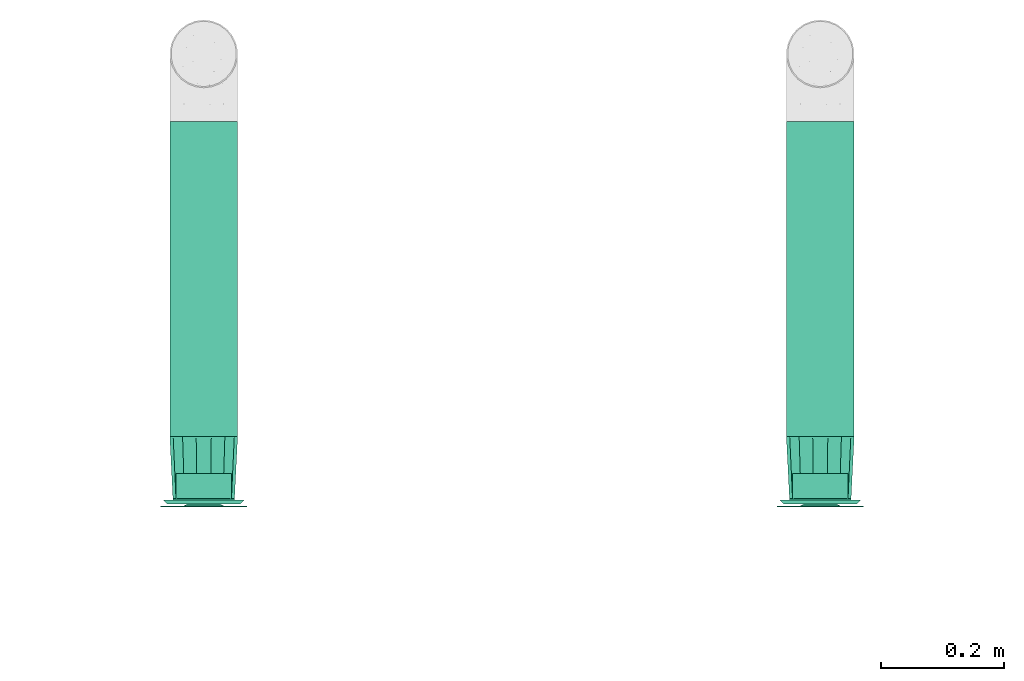
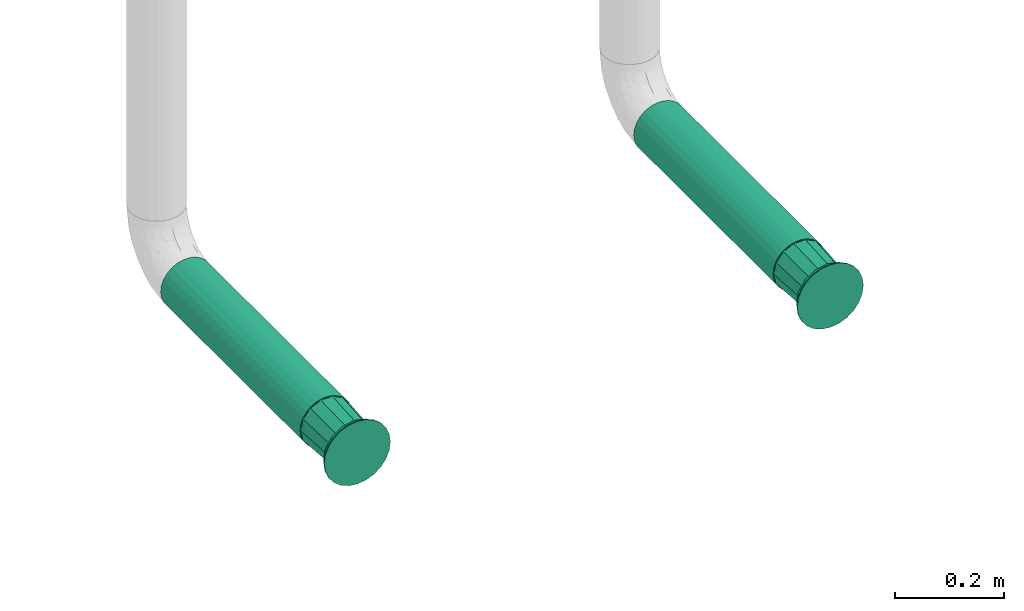
# One storey, part 86 of 115: 2 flow fittings, 2 flow segments, 2 flow terminals.
"""IFC2X3 building model written with IfcOpenShell, lengths in millimetres."""

from ifc_helpers import new_model, entity, si_unit, converted_unit, derived_unit, direction, frame, origin_with_axes, origin_2d_with_axis, place, context, subcontext, project, spatial, hollow_circle, extrude, open_shell, surface_model, source, transform, mapped, material, layer, layer_set, layer_usage, type_object, element, save


model = new_model("IFC2X3")

# Units and contexts
model_context = context("Model", 3, precision=1e-05, world=origin_with_axes(), true_north=direction((0.0, 1.0)))
body_context = subcontext(model_context, "Body", "Model", "MODEL_VIEW")
ifc_project = project(units=[si_unit("AREAUNIT", "SQUARE_METRE"), si_unit("VOLUMEUNIT", "CUBIC_METRE", prefix="DECI"), si_unit("TIMEUNIT", "SECOND"), si_unit("THERMODYNAMICTEMPERATUREUNIT", "DEGREE_CELSIUS"), si_unit("PRESSUREUNIT", "PASCAL"), si_unit("MASSUNIT", "GRAM", prefix="KILO"), si_unit("LENGTHUNIT", "METRE", prefix="MILLI"), si_unit("POWERUNIT", "WATT"), si_unit("ELECTRICCURRENTUNIT", "AMPERE"), si_unit("ELECTRICVOLTAGEUNIT", "VOLT"), derived_unit("VOLUMETRICFLOWRATEUNIT", [(si_unit("VOLUMEUNIT", "CUBIC_METRE", prefix="DECI"), 1), (si_unit("TIMEUNIT", "SECOND"), -1)]), derived_unit("LINEARVELOCITYUNIT", [(si_unit("LENGTHUNIT", "METRE"), 1), (si_unit("TIMEUNIT", "SECOND"), -1)]), derived_unit("MASSDENSITYUNIT", [(si_unit("MASSUNIT", "GRAM", prefix="KILO"), 1), (si_unit("VOLUMEUNIT", "CUBIC_METRE"), -1)]), converted_unit("PLANEANGLEUNIT", "DEGREE", entity("IfcRatioMeasure", 0.01745), si_unit("PLANEANGLEUNIT", "RADIAN"), dimensions=[0, 0, 0, 0, 0, 0, 0])], contexts=[model_context])

# Site, building, storey
site_placement = place(None, origin_with_axes())
site = spatial("IfcSite", under=ifc_project, at=site_placement, CompositionType="ELEMENT")
building_placement = place(site_placement, origin_with_axes())
building = spatial("IfcBuilding", under=site, at=building_placement, Name="mc-building", CompositionType="ELEMENT")
storey_placement = place(building_placement, frame((0.0, 0.0, 2950.0), z_axis=(0.0, 0.0, 1.0), x_axis=(1.0, 0.0, 0.0)))
storey = spatial("IfcBuildingStorey", under=building, at=storey_placement, Name="2. Korrus", CompositionType="ELEMENT", Elevation=2950.0)

# Flow terminals
air_terminal_type = type_object("IfcAirTerminalType", Name="100", PredefinedType="NOTDEFINED")
shared_shape_1 = source(origin_with_axes(), body_context, "Body", "SurfaceModel", [
    surface_model("IfcShellBasedSurfaceModel", [(11.2, 18.11733, -67.61481), (11.2, -18.11733, -67.61481), (11.2, 0.0, -70.0), (11.2, 67.61481, -18.11733), (11.2, 35.0, -60.62178), (11.2, 49.49747, -49.49747), (11.2, 60.62178, -35.0), (11.2, -67.61481, 18.11733), (11.2, -49.49747, -49.49747), (11.2, -67.61481, -18.11733), (11.2, -35.0, -60.62178), (11.2, -60.62178, -35.0), (11.2, -70.0, 0.0), (11.2, 18.11733, 67.61481), (11.2, 70.0, 0.0), (11.2, 67.61481, 18.11733), (11.2, 49.49747, 49.49747), (11.2, 60.62178, 35.0), (11.2, 35.0, 60.62178), (11.2, -49.49747, 49.49747), (11.2, -60.62178, 35.0), (11.2, -35.0, 60.62178), (11.2, -18.11733, 67.61481), (11.2, 0.0, 70.0), (9.2, 18.11733, 67.61481), (9.2, -67.61481, 18.11733), (9.2, 0.0, 70.0), (9.2, 49.49747, 49.49747), (9.2, 35.0, 60.62178), (9.2, 60.62178, 35.0), (9.2, 67.61481, 18.11733), (9.2, -35.0, 60.62178), (9.2, -49.49747, 49.49747), (9.2, -18.11733, 67.61481), (9.2, -60.62178, 35.0), (9.2, -67.61481, -18.11733), (9.2, -70.0, 0.0), (9.2, 67.61481, -18.11733), (9.2, 18.11733, -67.61481), (9.2, 49.49747, -49.49747), (9.2, 60.62178, -35.0), (9.2, 35.0, -60.62178), (9.2, -18.11733, -67.61481), (9.2, -49.49747, -49.49747), (9.2, -60.62178, -35.0), (9.2, -35.0, -60.62178), (9.2, 0.0, -70.0), (9.2, 70.0, 0.0), (9.2, 32.75, 0.0), (9.2, -16.375, 28.36233), (9.2, -28.36233, 16.375), (9.2, 16.375, 28.36233), (9.2, 0.0, 32.75), (9.2, 28.36233, 16.375), (9.2, -32.75, 0.0), (9.2, -16.375, -28.36233), (9.2, 16.375, -28.36233), (9.2, 0.0, -32.75), (9.2, 28.36233, -16.375), (9.2, -28.36233, -16.375), (6.2, -21.19625, -15.39997), (6.2, -21.19625, 15.39997), (6.2, 8.09625, 24.91768), (6.2, -8.09625, 24.91768), (6.2, -26.2, 0.0), (6.2, 21.19625, 15.39997), (6.2, -8.09625, -24.91768), (6.2, 21.19625, -15.39997), (6.2, 8.09625, -24.91768), (6.2, 26.2, 0.0), (9.2, 31.06579, -6.28555), (6.2, 23.69812, -7.69999), (6.2, -14.64625, -20.15883), (9.2, -22.36867, -22.36867), (6.2, -23.69812, -7.69999), (9.2, -31.06579, -6.28555), (6.2, 14.64625, -20.15883), (9.2, 8.1875, -30.55617), (6.2, 0.0, -24.91768), (9.2, 22.36867, -22.36867), (9.2, -8.1875, -30.55617), (9.2, -31.06579, 6.28555), (6.2, -23.69812, 7.69999), (6.2, 14.64625, 20.15883), (9.2, 22.36867, 22.36867), (6.2, 23.69812, 7.69999), (9.2, 31.06579, 6.28555), (6.2, -14.64625, 20.15883), (9.2, -8.1875, 30.55617), (6.2, 0.0, 24.91768), (9.2, -22.36867, 22.36867), (9.2, 8.1875, 30.55617), (6.2, -13.11761, 57.472), (6.2, -36.75472, 46.08897), (6.2, -53.11211, 25.57744), (6.2, 36.75472, 46.08897), (6.2, -58.95, 0.0), (6.2, 13.11761, 57.472), (6.2, 53.11211, 25.57744), (6.2, -53.11211, -25.57744), (6.2, -36.75472, -46.08897), (6.2, -13.11761, -57.472), (6.2, 58.95, 0.0), (6.2, 53.11211, -25.57744), (6.2, 13.11761, -57.472), (6.2, 36.75472, -46.08897), (0.0, -60.51411, 25.06576), (0.0, 0.0, 65.5), (0.0, 25.06576, 60.51411), (0.0, 46.3155, 46.3155), (0.0, 60.51411, 25.06576), (0.0, -46.3155, 46.3155), (0.0, -25.06576, 60.51411), (0.0, 0.0, -65.5), (0.0, -65.5, 0.0), (0.0, 65.5, 0.0), (0.0, 60.51411, -25.06576), (0.0, 46.3155, -46.3155), (0.0, 25.06576, -60.51411), (0.0, -46.3155, -46.3155), (0.0, -60.51411, -25.06576), (0.0, -25.06576, -60.51411), (6.2, 56.03105, -12.78872), (0.0, 53.4148, -35.69063), (0.0, 35.69063, -53.4148), (6.2, 24.93616, -51.78048), (0.0, -12.53288, -63.00706), (6.2, 0.0, -57.472), (0.0, -35.69063, -53.4148), (0.0, 63.00706, -12.53288), (6.2, 44.93342, -35.83321), (6.2, -24.93616, -51.78048), (6.2, -44.93342, -35.83321), (0.0, -53.4148, -35.69063), (0.0, 12.53288, -63.00706), (6.2, -56.03105, -12.78872), (0.0, -63.00706, -12.53288), (6.2, -56.03105, 12.78872), (0.0, -53.4148, 35.69063), (0.0, -35.69063, 53.4148), (6.2, -24.93616, 51.78048), (0.0, 12.53288, 63.00706), (6.2, 0.0, 57.472), (0.0, 35.69063, 53.4148), (0.0, -63.00706, 12.53288), (6.2, -44.93342, 35.83321), (6.2, 24.93616, 51.78048), (6.2, 44.93342, 35.83321), (0.0, 53.4148, 35.69063), (0.0, -12.53288, 63.00706), (6.2, 56.03105, 12.78872), (0.0, 63.00706, 12.53288), (-3.1, 12.94095, 48.29629), (-3.1, -35.35534, 35.35534), (-3.1, 0.0, 50.0), (-3.1, 35.35534, 35.35534), (-3.1, 25.0, 43.30127), (-3.1, -43.30127, 25.0), (-3.1, 43.30127, 25.0), (-3.1, -48.29629, -12.94095), (-3.1, -12.94095, 48.29629), (-3.1, -25.0, 43.30127), (-3.1, -50.0, 0.0), (-3.1, -48.29629, 12.94095), (-3.1, 48.29629, 12.94095), (-3.1, 12.94095, -48.29629), (-3.1, 50.0, 0.0), (-3.1, 48.29629, -12.94095), (-3.1, 35.35534, -35.35534), (-3.1, 43.30127, -25.0), (-3.1, 25.0, -43.30127), (-3.1, 0.0, -50.0), (-3.1, -35.35534, -35.35534), (-3.1, -43.30127, -25.0), (-3.1, -25.0, -43.30127), (-3.1, -12.94095, -48.29629), (0.0, 25.0, -43.30127), (0.0, 0.0, -50.0), (0.0, 12.94095, -48.29629), (0.0, 48.29629, -12.94095), (0.0, 35.35534, -35.35534), (0.0, -25.0, -43.30127), (0.0, 43.30127, -25.0), (0.0, -50.0, 0.0), (0.0, -12.94095, -48.29629), (0.0, -35.35534, -35.35534), (0.0, -48.29629, -12.94095), (0.0, -43.30127, -25.0), (0.0, 50.0, 0.0), (0.0, 43.30127, 25.0), (0.0, 12.94095, 48.29629), (0.0, 35.35534, 35.35534), (0.0, 25.0, 43.30127), (0.0, 0.0, 50.0), (0.0, -35.35534, 35.35534), (0.0, -43.30127, 25.0), (0.0, -48.29629, 12.94095), (0.0, -12.94095, 48.29629), (0.0, -25.0, 43.30127), (0.0, 48.29629, 12.94095), (-43.1, 0.0, 45.0), (-43.1, 11.64686, 43.46666), (-43.1, 22.5, 38.97115), (-43.1, -11.64686, 43.46666), (-43.1, 38.97115, 22.5), (-43.1, 43.46666, 11.64686), (-43.1, 31.81981, 31.81981), (-43.1, -22.5, 38.97115), (-43.1, -43.46666, 11.64686), (-43.1, -31.81981, 31.81981), (-43.1, -38.97115, 22.5), (-43.1, -45.0, 0.0), (-43.1, -43.46666, -11.64686), (-43.1, 45.0, 0.0), (-43.1, 43.46666, -11.64686), (-43.1, 38.97115, -22.5), (-43.1, 31.81981, -31.81981), (-43.1, 22.5, -38.97115), (-43.1, 11.64686, -43.46666), (-43.1, -31.81981, -31.81981), (-43.1, -38.97115, -22.5), (-43.1, -22.5, -38.97115), (-43.1, 0.0, -45.0), (-43.1, -11.64686, -43.46666), (-3.1, 22.5, -38.97115), (-3.1, 0.0, -45.0), (-3.1, 11.64686, -43.46666), (-3.1, 31.81981, -31.81981), (-3.1, -22.5, -38.97115), (-3.1, 38.97115, -22.5), (-3.1, 43.46666, -11.64686), (-3.1, 45.0, 0.0), (-3.1, -45.0, 0.0), (-3.1, -11.64686, -43.46666), (-3.1, -31.81981, -31.81981), (-3.1, -43.46666, -11.64686), (-3.1, -38.97115, -22.5), (-3.1, 0.0, 45.0), (-3.1, 43.46666, 11.64686), (-3.1, 38.97115, 22.5), (-3.1, 22.5, 38.97115), (-3.1, 31.81981, 31.81981), (-3.1, 11.64686, 43.46666), (-3.1, -11.64686, 43.46666), (-3.1, -43.46666, 11.64686), (-3.1, -31.81981, 31.81981), (-3.1, -38.97115, 22.5), (-3.1, -22.5, 38.97115)], [open_shell([[[0, 1, 2]], [[3, 0, 4]], [[5, 6, 3]], [[5, 3, 4]], [[7, 1, 0]], [[8, 7, 9]], [[10, 7, 8]], [[8, 9, 11]], [[12, 9, 7]], [[1, 7, 10]], [[7, 0, 3]], [[13, 14, 15]], [[16, 15, 17]], [[16, 18, 13]], [[16, 13, 15]], [[14, 13, 7]], [[7, 19, 20]], [[19, 7, 21]], [[7, 22, 21]], [[22, 7, 23]], [[7, 13, 23]], [[14, 7, 3]], [[24, 25, 26]], [[27, 24, 28]], [[27, 29, 30]], [[27, 30, 24]], [[25, 24, 30]], [[31, 25, 32]], [[25, 31, 33]], [[32, 25, 34]], [[33, 26, 25]], [[25, 35, 36]], [[25, 30, 37]], [[25, 37, 38]], [[39, 37, 40]], [[39, 41, 38]], [[39, 38, 37]], [[38, 42, 25]], [[35, 43, 44]], [[35, 25, 43]], [[45, 43, 25]], [[42, 45, 25]], [[38, 46, 42]], [[37, 30, 47]], [[35, 9, 36]], [[44, 11, 35]], [[10, 43, 45]], [[44, 43, 8]], [[1, 45, 42]], [[35, 11, 9]], [[9, 12, 36]], [[1, 10, 45]], [[8, 43, 10]], [[8, 11, 44]], [[2, 1, 42]], [[42, 46, 2]], [[38, 0, 46]], [[41, 4, 38]], [[6, 39, 40]], [[41, 39, 5]], [[3, 40, 37]], [[41, 5, 4]], [[4, 0, 38]], [[14, 3, 37]], [[6, 40, 3]], [[6, 5, 39]], [[47, 14, 37]], [[46, 0, 2]], [[30, 15, 47]], [[29, 17, 30]], [[18, 27, 28]], [[29, 27, 16]], [[13, 28, 24]], [[30, 17, 15]], [[15, 14, 47]], [[13, 18, 28]], [[16, 27, 18]], [[16, 17, 29]], [[23, 13, 24]], [[24, 26, 23]], [[33, 22, 26]], [[31, 21, 33]], [[20, 32, 34]], [[31, 32, 19]], [[7, 34, 25]], [[31, 19, 21]], [[21, 22, 33]], [[12, 7, 25]], [[20, 34, 7]], [[20, 19, 32]], [[36, 12, 25]], [[26, 22, 23]], [[48, 49, 50]], [[48, 51, 49]], [[49, 51, 52]], [[53, 51, 48]], [[48, 50, 54]], [[54, 55, 48]], [[56, 55, 57]], [[55, 58, 48]], [[58, 55, 56]], [[55, 54, 59]], [[60, 61, 62]], [[62, 61, 63]], [[64, 61, 60]], [[62, 65, 66]], [[67, 68, 65]], [[66, 60, 62]], [[65, 68, 66]], [[69, 67, 65]], [[69, 48, 70]], [[58, 71, 70]], [[72, 73, 60]], [[59, 74, 60]], [[75, 64, 74]], [[56, 68, 76]], [[72, 66, 55]], [[73, 72, 55]], [[68, 77, 78]], [[64, 75, 54]], [[59, 75, 74]], [[70, 71, 69]], [[67, 79, 76]], [[80, 55, 66]], [[68, 56, 77]], [[56, 76, 79]], [[79, 67, 58]], [[71, 58, 67]], [[80, 78, 57]], [[77, 57, 78]], [[66, 78, 80]], [[59, 60, 73]], [[64, 54, 81]], [[50, 82, 81]], [[83, 84, 65]], [[53, 85, 65]], [[86, 69, 85]], [[49, 63, 87]], [[83, 62, 51]], [[84, 83, 51]], [[63, 88, 89]], [[69, 86, 48]], [[53, 86, 85]], [[81, 82, 64]], [[61, 90, 87]], [[91, 51, 62]], [[63, 49, 88]], [[49, 87, 90]], [[90, 61, 50]], [[82, 50, 61]], [[91, 89, 52]], [[88, 52, 89]], [[62, 89, 91]], [[53, 65, 84]], [[92, 93, 94]], [[95, 94, 96]], [[97, 92, 95]], [[95, 92, 94]], [[96, 98, 95]], [[96, 99, 98]], [[99, 100, 101]], [[101, 102, 98]], [[102, 101, 103]], [[104, 105, 103]], [[101, 104, 103]], [[101, 98, 99]], [[106, 107, 108]], [[109, 110, 108]], [[106, 108, 110]], [[111, 112, 106]], [[106, 112, 107]], [[106, 113, 114]], [[106, 110, 113]], [[115, 116, 117]], [[117, 113, 110]], [[113, 117, 118]], [[114, 119, 120]], [[121, 119, 114]], [[121, 114, 113]], [[115, 117, 110]], [[103, 116, 122]], [[123, 116, 103]], [[124, 125, 118]], [[101, 126, 127]], [[100, 119, 128]], [[102, 122, 129]], [[103, 130, 123]], [[102, 129, 115]], [[113, 127, 126]], [[125, 124, 105]], [[130, 105, 117]], [[118, 125, 104]], [[124, 117, 105]], [[131, 100, 128]], [[119, 100, 132]], [[133, 99, 120]], [[134, 118, 104]], [[122, 116, 129]], [[127, 134, 104]], [[131, 121, 101]], [[99, 133, 132]], [[128, 121, 131]], [[130, 117, 123]], [[101, 121, 126]], [[99, 135, 120]], [[96, 136, 135]], [[136, 120, 135]], [[134, 127, 113]], [[133, 119, 132]], [[136, 96, 114]], [[94, 106, 137]], [[138, 106, 94]], [[139, 140, 112]], [[97, 141, 142]], [[95, 109, 143]], [[96, 137, 144]], [[94, 145, 138]], [[96, 144, 114]], [[107, 142, 141]], [[140, 139, 93]], [[145, 93, 111]], [[112, 140, 92]], [[139, 111, 93]], [[146, 95, 143]], [[109, 95, 147]], [[148, 98, 110]], [[149, 112, 92]], [[137, 106, 144]], [[142, 149, 92]], [[146, 108, 97]], [[98, 148, 147]], [[143, 108, 146]], [[145, 111, 138]], [[97, 108, 141]], [[98, 150, 110]], [[102, 151, 150]], [[151, 110, 150]], [[149, 142, 107]], [[148, 109, 147]], [[151, 102, 115]], [[152, 153, 154]], [[155, 152, 156]], [[157, 152, 158]], [[158, 152, 155]], [[158, 159, 157]], [[160, 153, 161]], [[160, 154, 153]], [[157, 162, 163]], [[153, 152, 157]], [[157, 159, 162]], [[158, 164, 159]], [[165, 166, 167]], [[168, 167, 169]], [[170, 165, 167]], [[170, 167, 168]], [[166, 165, 171]], [[159, 172, 173]], [[172, 159, 174]], [[174, 171, 175]], [[159, 164, 174]], [[166, 171, 174]], [[174, 164, 166]], [[176, 177, 178]], [[179, 176, 180]], [[176, 179, 181]], [[179, 180, 182]], [[179, 183, 181]], [[177, 181, 184]], [[177, 176, 181]], [[185, 186, 187]], [[186, 185, 181]], [[181, 183, 186]], [[183, 179, 188]], [[183, 188, 189]], [[190, 189, 191]], [[189, 190, 183]], [[190, 191, 192]], [[193, 194, 190]], [[183, 195, 196]], [[183, 190, 195]], [[194, 197, 198]], [[194, 195, 190]], [[197, 194, 193]], [[189, 188, 199]], [[164, 199, 166]], [[158, 189, 164]], [[192, 155, 156]], [[158, 155, 191]], [[190, 156, 152]], [[164, 189, 199]], [[199, 188, 166]], [[190, 192, 156]], [[191, 155, 192]], [[191, 189, 158]], [[193, 190, 152]], [[152, 154, 193]], [[160, 197, 154]], [[161, 198, 160]], [[195, 153, 157]], [[161, 153, 194]], [[196, 157, 163]], [[161, 194, 198]], [[198, 197, 160]], [[183, 196, 163]], [[195, 157, 196]], [[195, 194, 153]], [[162, 183, 163]], [[154, 197, 193]], [[159, 186, 162]], [[173, 187, 159]], [[181, 172, 174]], [[173, 172, 185]], [[184, 174, 175]], [[159, 187, 186]], [[186, 183, 162]], [[184, 181, 174]], [[185, 172, 181]], [[185, 187, 173]], [[177, 184, 175]], [[175, 171, 177]], [[165, 178, 171]], [[170, 176, 165]], [[182, 168, 169]], [[170, 168, 180]], [[179, 169, 167]], [[170, 180, 176]], [[176, 178, 165]], [[188, 179, 167]], [[182, 169, 179]], [[182, 180, 168]], [[166, 188, 167]], [[171, 178, 177]], [[200, 201, 202]], [[203, 200, 202]], [[204, 205, 202]], [[204, 202, 206]], [[203, 202, 205]], [[207, 208, 209]], [[207, 203, 205]], [[209, 208, 210]], [[211, 208, 212]], [[208, 207, 212]], [[207, 205, 212]], [[213, 214, 215]], [[205, 215, 212]], [[212, 216, 217]], [[216, 212, 215]], [[218, 219, 217]], [[212, 219, 220]], [[212, 217, 219]], [[221, 222, 223]], [[222, 221, 219]], [[218, 222, 219]], [[215, 205, 213]], [[224, 225, 226]], [[227, 228, 224]], [[229, 230, 231]], [[228, 227, 229]], [[229, 232, 228]], [[225, 228, 233]], [[225, 224, 228]], [[234, 235, 236]], [[235, 234, 228]], [[228, 232, 235]], [[232, 229, 231]], [[237, 238, 239]], [[240, 239, 241]], [[240, 242, 237]], [[240, 237, 239]], [[238, 237, 243]], [[244, 245, 246]], [[247, 244, 232]], [[244, 247, 245]], [[232, 238, 247]], [[238, 243, 247]], [[238, 232, 231]], [[205, 238, 213]], [[204, 239, 205]], [[240, 206, 202]], [[204, 206, 241]], [[242, 202, 201]], [[205, 239, 238]], [[238, 231, 213]], [[240, 202, 242]], [[241, 206, 240]], [[241, 239, 204]], [[201, 237, 242]], [[201, 200, 237]], [[243, 203, 207]], [[209, 247, 207]], [[246, 210, 208]], [[209, 210, 245]], [[244, 208, 211]], [[203, 243, 200]], [[207, 247, 243]], [[200, 243, 237]], [[209, 245, 247]], [[210, 246, 245]], [[244, 246, 208]], [[211, 232, 244]], [[212, 235, 211]], [[220, 236, 212]], [[228, 219, 221]], [[220, 219, 234]], [[233, 221, 223]], [[212, 236, 235]], [[235, 232, 211]], [[233, 228, 221]], [[234, 219, 228]], [[234, 236, 220]], [[225, 233, 223]], [[223, 222, 225]], [[226, 218, 217]], [[216, 224, 217]], [[229, 215, 214]], [[216, 215, 227]], [[230, 214, 213]], [[218, 226, 222]], [[217, 224, 226]], [[222, 226, 225]], [[216, 227, 224]], [[215, 229, 227]], [[230, 229, 214]], [[213, 231, 230]]])]),
])
for number, where, z_axis, x_axis, name in (
    (1, (23757.14677, 12939.66532, 2300.0), (0.0, 0.0, 1.0), (0.0, -1.0, 0.0), "100"),
    (2, (22757.14677, 12939.66532, 2300.0), (0.0, 0.0, 1.0), (0.0, -1.0, 0.0), "100"),
):
    element("IfcFlowTerminal", number, at=place(storey_placement, frame(where, z_axis=z_axis, x_axis=x_axis)), inside=storey, type_object=air_terminal_type, Name=name, context=body_context, shape_type="MappedRepresentation", body=[
        mapped(shared_shape_1, transform((0.0, 0.0, 0.0), scale=1.0)),
    ])

# Flow segments
ifc_material = material(Name="FZ1")
ifc_layer = layer(ifc_material, 0.0)
ifc_layer_set = layer_set([ifc_layer], Name="FZ1")
ifc_layer_usage = layer_usage(ifc_layer_set, "AXIS1", "POSITIVE", 0.0)
duct_segment_type = type_object("IfcDuctSegmentType", PredefinedType="RIGIDSEGMENT")
shared_shape_2 = source(origin_with_axes(), body_context, "Body", "SweptSolid", [
    extrude(hollow_circle(Radius=55.0, WallThickness=2.0, at=origin_2d_with_axis()), frame((0.0, 0.0, 0.0), z_axis=(1.0, 0.0, 0.0), x_axis=(0.0, 1.0, 0.0)), (0.0, 0.0, 1.0), 510.8),
])
for number, where, z_axis, x_axis in (
    (3, (23757.14677, 13042.76532, 2300.0), (0.0, 0.0, 1.0), (0.0, 1.0, 0.0)),
    (4, (22757.14677, 13042.76532, 2300.0), (0.0, 0.0, 1.0), (0.0, 1.0, 0.0)),
):
    element("IfcFlowSegment", number, at=place(storey_placement, frame(where, z_axis=z_axis, x_axis=x_axis)), inside=storey, type_object=duct_segment_type, material=ifc_layer_usage, context=body_context, shape_type="MappedRepresentation", body=[
        mapped(shared_shape_2, transform((0.0, 0.0, 0.0), scale=1.0)),
    ])

# Flow fittings
duct_fitting_type = type_object("IfcDuctFittingType", PredefinedType="TRANSITION")
shared_shape_3 = source(origin_with_axes(), body_context, "Body", "SurfaceModel", [
    surface_model("IfcShellBasedSurfaceModel", [(0.0, 12.94095, 48.29629), (0.0, -35.35534, 35.35534), (0.0, 0.0, 50.0), (0.0, 35.35534, 35.35534), (0.0, 25.0, 43.30127), (0.0, 43.30127, 25.0), (0.0, 48.29629, 12.94095), (0.0, -12.94095, 48.29629), (0.0, -25.0, 43.30127), (0.0, -48.29629, 12.94095), (0.0, -43.30127, 25.0), (0.0, -25.0, -43.30127), (0.0, -48.29629, -12.94095), (0.0, -50.0, 0.0), (0.0, 48.29629, -12.94095), (0.0, 12.94095, -48.29629), (0.0, 43.30127, -25.0), (0.0, 35.35534, -35.35534), (0.0, 25.0, -43.30127), (0.0, -35.35534, -35.35534), (0.0, -43.30127, -25.0), (0.0, -12.94095, -48.29629), (0.0, 0.0, -50.0), (0.0, 50.0, 0.0), (100.0, -55.0, 0.0), (100.0, -12.23865, 53.62104), (100.0, -34.29194, 43.00073), (100.0, 49.55329, -23.86361), (100.0, 12.23865, 53.62104), (100.0, 34.29194, 43.00073), (100.0, 55.0, 0.0), (100.0, 49.55329, 23.86361), (100.0, -49.55329, 23.86361), (100.0, 12.23865, -53.62104), (100.0, -49.55329, -23.86361), (100.0, -34.29194, -43.00073), (100.0, 34.29194, -43.00073), (100.0, -12.23865, -53.62104), (0.0, 11.12605, 48.7464), (0.0, -11.12605, 48.7464), (0.0, 31.17449, 39.09157), (0.0, -45.04844, -21.69419), (0.0, -45.04844, 21.69419), (0.0, -31.17449, 39.09157), (0.0, 45.04844, 21.69419), (0.0, 45.04844, -21.69419), (0.0, 31.17449, -39.09157), (0.0, -31.17449, -39.09157), (0.0, -11.12605, -48.7464), (0.0, 11.12605, -48.7464), (0.0, -47.52422, -10.84709), (100.0, -41.92261, -33.43217), (0.0, -38.11147, -30.39288), (100.0, 41.92261, -33.43217), (0.0, 38.11147, -30.39288), (0.0, -21.15027, -43.91899), (100.0, -23.2653, -48.31088), (100.0, -52.32388, -11.72483), (100.0, 0.0, -53.62104), (0.0, 0.0, -48.7464), (100.0, 23.2653, -48.31088), (0.0, 21.15027, -43.91899), (100.0, 52.32388, -11.72483), (0.0, 47.52422, -10.84709), (0.0, 47.52422, 10.84709), (100.0, 41.92261, 33.43217), (0.0, 38.11147, 30.39288), (100.0, -41.92261, 33.43217), (0.0, -38.11147, 30.39288), (0.0, 21.15027, 43.91899), (100.0, 23.2653, 48.31088), (100.0, 52.32388, 11.72483), (100.0, 0.0, 53.62104), (0.0, 0.0, 48.7464), (100.0, -23.2653, 48.31088), (0.0, -21.15027, 43.91899), (100.0, -52.32388, 11.72483), (0.0, -47.52422, 10.84709), (100.0, 27.5, -47.63139), (100.0, 0.0, -55.0), (100.0, 14.23505, -53.12592), (100.0, 38.89087, -38.89087), (100.0, -27.5, -47.63139), (100.0, 47.63139, -27.5), (100.0, 53.12592, -14.23505), (100.0, -14.23505, -53.12592), (100.0, -47.63139, -27.5), (100.0, -38.89087, -38.89087), (100.0, -53.12592, -14.23505), (100.0, 53.12592, 14.23505), (100.0, 47.63139, 27.5), (100.0, 27.5, 47.63139), (100.0, 38.89087, 38.89087), (100.0, 14.23505, 53.12592), (100.0, 0.0, 55.0), (100.0, -47.63139, 27.5), (100.0, -53.12592, 14.23505), (100.0, -27.5, 47.63139), (100.0, -38.89087, 38.89087), (100.0, -14.23505, 53.12592), (98.0, 0.0, 55.0), (98.0, 14.23505, 53.12592), (98.0, 27.5, 47.63139), (98.0, 38.89087, 38.89087), (98.0, 47.63139, 27.5), (98.0, -47.63139, 27.5), (98.0, 53.12592, -14.23505), (98.0, -27.5, 47.63139), (98.0, -14.23505, 53.12592), (98.0, -38.89087, 38.89087), (98.0, -55.0, 0.0), (98.0, -53.12592, 14.23505), (98.0, 53.12592, 14.23505), (98.0, 47.63139, -27.5), (98.0, -27.5, -47.63139), (98.0, 0.0, -55.0), (98.0, 38.89087, -38.89087), (98.0, 27.5, -47.63139), (98.0, 14.23505, -53.12592), (98.0, -47.63139, -27.5), (98.0, -38.89087, -38.89087), (98.0, -53.12592, -14.23505), (98.0, -14.23505, -53.12592), (98.0, 55.0, 0.0), (2.0, 12.94095, -48.29629), (2.0, 25.0, -43.30127), (2.0, 35.35534, -35.35534), (2.0, 43.30127, -25.0), (2.0, 48.29629, -12.94095), (2.0, 0.0, -50.0), (2.0, 50.0, 0.0), (2.0, -25.0, -43.30127), (2.0, -12.94095, -48.29629), (2.0, -35.35534, -35.35534), (2.0, -48.29629, -12.94095), (2.0, -43.30127, -25.0), (2.0, -48.29629, 12.94095), (2.0, 48.29629, 12.94095), (2.0, 43.30127, 25.0), (2.0, 35.35534, 35.35534), (2.0, -35.35534, 35.35534), (2.0, 12.94095, 48.29629), (2.0, 25.0, 43.30127), (2.0, 0.0, 50.0), (2.0, -43.30127, 25.0), (2.0, -50.0, 0.0), (2.0, -12.94095, 48.29629), (2.0, -25.0, 43.30127)], [open_shell([[[0, 1, 2]], [[3, 0, 4]], [[3, 5, 6]], [[0, 3, 1]], [[6, 1, 3]], [[7, 1, 8]], [[7, 2, 1]], [[1, 9, 10]], [[9, 1, 11]], [[12, 13, 9]], [[11, 1, 6]], [[6, 14, 11]], [[15, 14, 16]], [[17, 18, 15]], [[17, 15, 16]], [[11, 14, 15]], [[12, 19, 20]], [[19, 12, 11]], [[15, 21, 11]], [[12, 9, 11]], [[22, 21, 15]], [[14, 6, 23]], [[24, 25, 26]], [[25, 27, 28]], [[29, 28, 27]], [[27, 30, 31]], [[31, 29, 27]], [[24, 26, 32]], [[33, 24, 34]], [[33, 34, 35]], [[36, 27, 33]], [[33, 27, 24]], [[35, 37, 33]], [[24, 27, 25]], [[38, 23, 39]], [[40, 23, 38]], [[41, 42, 43]], [[41, 13, 42]], [[23, 43, 39]], [[40, 44, 23]], [[41, 23, 45]], [[41, 45, 46]], [[47, 41, 48]], [[49, 48, 41]], [[41, 46, 49]], [[23, 41, 43]], [[34, 50, 41]], [[47, 51, 52]], [[45, 27, 53]], [[36, 54, 53]], [[55, 48, 56]], [[34, 57, 50]], [[57, 13, 50]], [[13, 57, 24]], [[55, 35, 47]], [[35, 51, 47]], [[51, 41, 52]], [[58, 59, 49]], [[60, 61, 46]], [[37, 59, 58]], [[62, 63, 23]], [[35, 55, 56]], [[23, 30, 62]], [[53, 54, 45]], [[48, 37, 56]], [[33, 49, 61]], [[49, 33, 58]], [[54, 36, 46]], [[63, 27, 45]], [[34, 41, 51]], [[33, 61, 60]], [[48, 59, 37]], [[27, 63, 62]], [[46, 36, 60]], [[31, 64, 44]], [[40, 65, 66]], [[42, 32, 67]], [[26, 68, 67]], [[69, 38, 70]], [[31, 71, 64]], [[71, 23, 64]], [[23, 71, 30]], [[69, 29, 40]], [[29, 65, 40]], [[65, 44, 66]], [[72, 73, 39]], [[74, 75, 43]], [[28, 73, 72]], [[76, 77, 13]], [[29, 69, 70]], [[13, 24, 76]], [[67, 68, 42]], [[38, 28, 70]], [[25, 39, 75]], [[39, 25, 72]], [[68, 26, 43]], [[77, 32, 42]], [[31, 44, 65]], [[25, 75, 74]], [[38, 73, 28]], [[32, 77, 76]], [[43, 26, 74]], [[78, 79, 80]], [[81, 82, 78]], [[82, 83, 84]], [[81, 83, 82]], [[30, 82, 84]], [[79, 82, 85]], [[79, 78, 82]], [[82, 86, 87]], [[82, 30, 86]], [[24, 88, 86]], [[86, 30, 89]], [[90, 24, 89]], [[91, 90, 92]], [[91, 93, 94]], [[90, 91, 24]], [[94, 95, 91]], [[24, 95, 96]], [[24, 91, 95]], [[94, 97, 98]], [[98, 95, 94]], [[97, 94, 99]], [[89, 24, 86]], [[100, 101, 102]], [[100, 102, 103]], [[100, 104, 105]], [[104, 100, 103]], [[106, 105, 104]], [[100, 107, 108]], [[100, 109, 107]], [[105, 110, 111]], [[109, 100, 105]], [[105, 106, 110]], [[106, 104, 112]], [[106, 113, 110]], [[113, 114, 110]], [[115, 116, 117]], [[113, 116, 115]], [[117, 118, 115]], [[119, 114, 120]], [[121, 110, 119]], [[114, 115, 122]], [[119, 110, 114]], [[115, 114, 113]], [[123, 106, 112]], [[121, 88, 110]], [[119, 86, 121]], [[82, 120, 114]], [[119, 120, 87]], [[85, 114, 122]], [[121, 86, 88]], [[88, 24, 110]], [[85, 82, 114]], [[87, 120, 82]], [[87, 86, 119]], [[79, 85, 122]], [[122, 115, 79]], [[118, 80, 115]], [[117, 78, 118]], [[83, 116, 113]], [[117, 116, 81]], [[84, 113, 106]], [[117, 81, 78]], [[78, 80, 118]], [[30, 84, 106]], [[83, 113, 84]], [[83, 81, 116]], [[123, 30, 106]], [[115, 80, 79]], [[112, 89, 123]], [[104, 90, 112]], [[91, 103, 102]], [[104, 103, 92]], [[93, 102, 101]], [[112, 90, 89]], [[89, 30, 123]], [[93, 91, 102]], [[92, 103, 91]], [[92, 90, 104]], [[94, 93, 101]], [[101, 100, 94]], [[108, 99, 100]], [[107, 97, 108]], [[95, 109, 105]], [[107, 109, 98]], [[96, 105, 111]], [[107, 98, 97]], [[97, 99, 108]], [[24, 96, 111]], [[95, 105, 96]], [[95, 98, 109]], [[110, 24, 111]], [[100, 99, 94]], [[124, 125, 126]], [[124, 126, 127]], [[124, 128, 129]], [[128, 124, 127]], [[129, 128, 130]], [[129, 131, 132]], [[129, 130, 131]], [[133, 134, 135]], [[134, 133, 131]], [[131, 136, 134]], [[131, 130, 137]], [[137, 138, 139]], [[140, 137, 139]], [[140, 139, 141]], [[141, 139, 142]], [[140, 141, 143]], [[136, 140, 144]], [[145, 134, 136]], [[140, 146, 147]], [[131, 140, 136]], [[143, 146, 140]], [[131, 137, 140]], [[12, 134, 13]], [[20, 135, 12]], [[131, 19, 11]], [[20, 19, 133]], [[132, 11, 21]], [[12, 135, 134]], [[134, 145, 13]], [[132, 131, 11]], [[133, 19, 131]], [[133, 135, 20]], [[129, 132, 21]], [[21, 22, 129]], [[15, 124, 22]], [[18, 125, 15]], [[127, 17, 16]], [[18, 17, 126]], [[128, 16, 14]], [[18, 126, 125]], [[125, 124, 15]], [[130, 128, 14]], [[127, 16, 128]], [[127, 126, 17]], [[23, 130, 14]], [[22, 124, 129]], [[6, 137, 23]], [[5, 138, 6]], [[142, 3, 4]], [[5, 3, 139]], [[141, 4, 0]], [[6, 138, 137]], [[137, 130, 23]], [[141, 142, 4]], [[139, 3, 142]], [[139, 138, 5]], [[143, 141, 0]], [[0, 2, 143]], [[7, 146, 2]], [[8, 147, 7]], [[144, 1, 10]], [[8, 1, 140]], [[136, 10, 9]], [[8, 140, 147]], [[147, 146, 7]], [[145, 136, 9]], [[144, 10, 136]], [[144, 140, 1]], [[13, 145, 9]], [[2, 146, 143]]])]),
])
for number, where, z_axis, x_axis in (
    (5, (23757.14677, 12942.76532, 2300.0), (0.0, 0.0, 1.0), (0.0, 1.0, 0.0)),
    (6, (22757.14677, 12942.76532, 2300.0), (0.0, 0.0, 1.0), (0.0, 1.0, 0.0)),
):
    element("IfcFlowFitting", number, at=place(storey_placement, frame(where, z_axis=z_axis, x_axis=x_axis)), inside=storey, type_object=duct_fitting_type, context=body_context, shape_type="MappedRepresentation", body=[
        mapped(shared_shape_3, transform((0.0, 0.0, 0.0), scale=1.0)),
    ])

save(model, "model.ifc")
